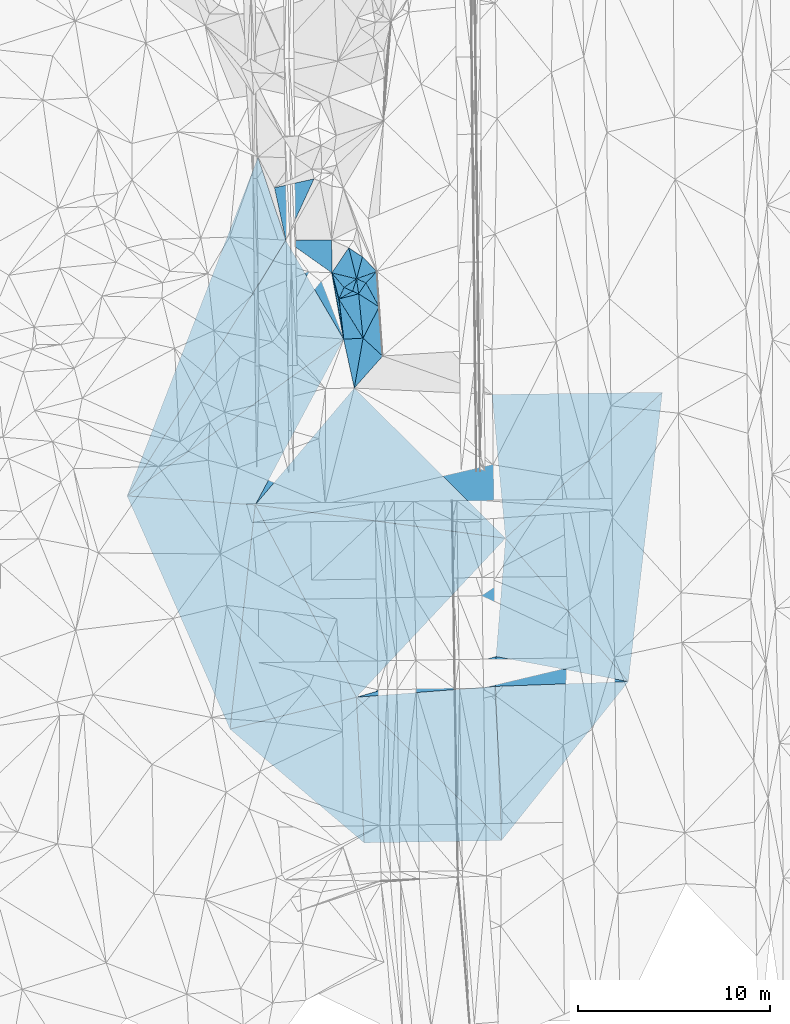
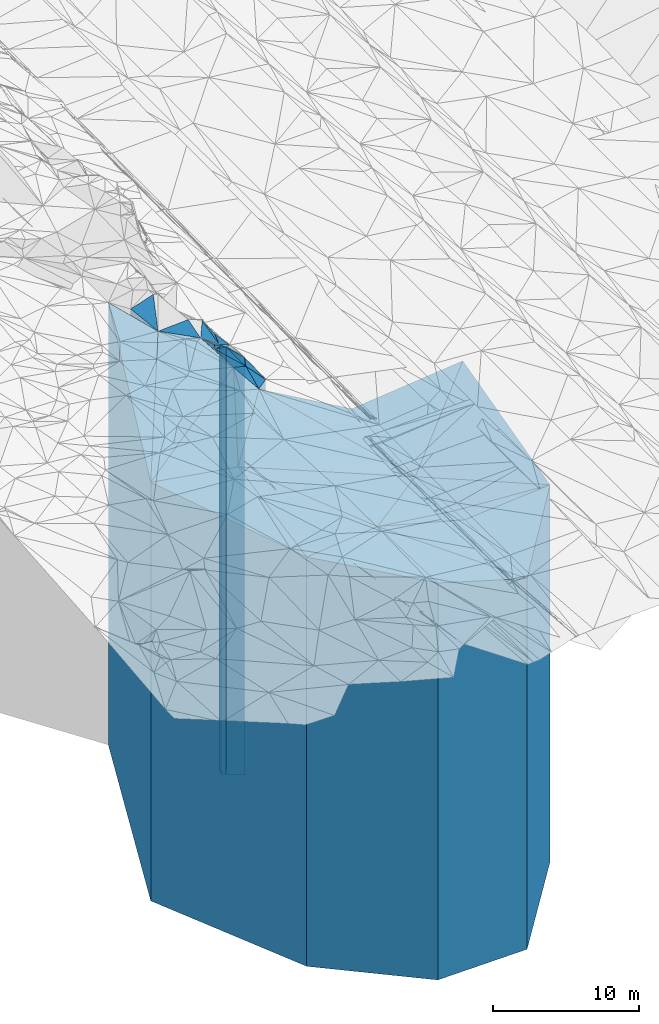
# One storey, part 196 of 275: 42 plates.
"""IFC2X3 building model written with IfcOpenShell, lengths in millimetres."""

from ifc_helpers import new_model, si_unit, frame, origin_with_axes, place, context, subcontext, project, spatial, faceted_brep, material, type_object, element, save


model = new_model("IFC2X3")

# Units and contexts
model_context = context("Model", 3, precision=1e-05, world=origin_with_axes())
body_context = subcontext(model_context, "Body", "Model", "MODEL_VIEW")
ifc_project = project(units=[si_unit("LENGTHUNIT", "METRE", prefix="MILLI"), si_unit("AREAUNIT", "SQUARE_METRE"), si_unit("VOLUMEUNIT", "CUBIC_METRE"), si_unit("MASSUNIT", "GRAM", prefix="KILO"), si_unit("TIMEUNIT", "SECOND"), si_unit("PLANEANGLEUNIT", "RADIAN"), si_unit("SOLIDANGLEUNIT", "STERADIAN"), si_unit("THERMODYNAMICTEMPERATUREUNIT", "DEGREE_CELSIUS"), si_unit("LUMINOUSINTENSITYUNIT", "LUMEN")], contexts=[model_context])

# Site, building, storey
site_placement = place(None, origin_with_axes())
site = spatial("IfcSite", under=ifc_project, at=site_placement, CompositionType="ELEMENT")
building_placement = place(site_placement, origin_with_axes())
building = spatial("IfcBuilding", under=site, at=building_placement, Name="Undefined", CompositionType="ELEMENT")
storey_placement = place(building_placement, origin_with_axes())
storey = spatial("IfcBuildingStorey", under=building, at=storey_placement, Name="Undefined", CompositionType="ELEMENT", Elevation=0.0)

# Plates
ifc_material = material()
plate_type_1 = type_object("IfcPlateType", PredefinedType="NOTDEFINED")
plate_1_placement = place(storey_placement, frame((-105305.526573937, -440.815138001315, 24982.5), z_axis=(-0.0700177739983117, -0.997545743975845, 0.0), x_axis=(-0.997545743975845, 0.0700177739983046, 0.0)))
element("IfcPlate", 1, at=plate_1_placement, inside=storey, type_object=plate_type_1, material=ifc_material, Name="00", context=body_context, shape_type="Brep", body=[
    faceted_brep([(1.45519152283669e-11, -17177.9519996643, 0.0), (491.817077636646, -17154.5, 11731.232421875), (491.817077636646, 17154.5, 11731.232421875), (1.45519152283669e-11, 17154.5, 0.0), (6685.89746093751, -17935.7919921875, 2.03817762667313e-08), (6685.89746093751, 17154.5, 2.03817762667313e-08)], [[[0, 1, 2, 3]], [[1, 4, 5, 2]], [[4, 0, 3, 5]], [[5, 3, 2]], [[4, 1, 0]]]),
])
plate_type_2 = type_object("IfcPlateType", PredefinedType="NOTDEFINED")
plate_2_placement = place(storey_placement, frame((-99640.6124086011, -18023.9448640923, 23363.5), z_axis=(-0.0167956189939975, 0.999858943642856, 0.0), x_axis=(0.999858943642856, 0.0167956189940008, 0.0)))
element("IfcPlate", 2, at=plate_2_placement, inside=storey, type_object=plate_type_2, material=ifc_material, Name="00", context=body_context, shape_type="Brep", body=[
    faceted_brep([(0.0, -17744.5048828125, -3.63797880709171e-12), (-275.485351562515, -18023.1530761719, 7580.67138671875), (-275.485351562515, 15535.5, 7580.67138671875), (0.0, 15535.5, -3.63797880709171e-12), (7152.96582031251, -15535.5, -7.49605533201247e-09), (7152.96582031251, 15535.5, -7.49605533201247e-09)], [[[0, 1, 2, 3]], [[1, 4, 5, 2]], [[4, 0, 3, 5]], [[5, 3, 2]], [[4, 1, 0]]]),
])
plate_type_3 = type_object("IfcPlateType", PredefinedType="NOTDEFINED")
plate_3_placement = place(storey_placement, frame((-92802.1248192446, -9884.44215009389, 23343.5), z_axis=(-0.0364740679928173, 0.999334599803317, 0.0), x_axis=(0.999334599803317, 0.0364740679928213, 0.0)))
element("IfcPlate", 3, at=plate_3_placement, inside=storey, type_object=plate_type_3, material=ifc_material, Name="00", context=body_context, shape_type="Brep", body=[
    faceted_brep([(-1.45519152283669e-11, -15739.6970062256, -2.72848410531878e-12), (79.7649078368995, -15515.5, 1552.5810546875), (79.7649078368995, 15515.5, 1552.5810546875), (-1.45519152283669e-11, 15515.5, -2.72848410531878e-12), (6914.56884765624, -16092.4429931641, -2.303841029061e-08), (6914.56884765624, 15515.5, -2.303841029061e-08)], [[[0, 1, 2, 3]], [[1, 4, 5, 2]], [[4, 0, 3, 5]], [[5, 3, 2]], [[4, 1, 0]]]),
])
plate_type_4 = type_object("IfcPlateType", PredefinedType="NOTDEFINED")
plate_4_placement = place(storey_placement, frame((-92802.1248192446, -9884.44215009389, 23343.5), z_axis=(-0.999889764673586, 0.0148478449951532, 0.0), x_axis=(0.0148478449951493, 0.999889764673586, 0.0)))
element("IfcPlate", 4, at=plate_4_placement, inside=storey, type_object=plate_type_4, material=ifc_material, Name="00", context=body_context, shape_type="Brep", body=[
    faceted_brep([(-1.45519152283669e-11, -15739.6970062256, -2.72848410531878e-12), (-671.982604980498, -18043.2661132813, 7232.07568359378), (-671.982604980498, 15515.5, 7232.07568359378), (-1.45519152283669e-11, 15515.5, -2.72848410531878e-12), (1554.62878417969, -15515.5, 1.44063960760832e-09), (1554.62878417969, 15515.5, 1.44063960760832e-09)], [[[0, 1, 2, 3]], [[1, 4, 5, 2]], [[4, 0, 3, 5]], [[5, 3, 2]], [[4, 1, 0]]]),
])
plate_type_5 = type_object("IfcPlateType", PredefinedType="NOTDEFINED")
plate_5_placement = place(storey_placement, frame((-92779.0419328153, -8329.98478390302, 22828.0), z_axis=(-0.996761812388552, 0.0804107540313459, 0.0), x_axis=(0.0804107540313444, 0.996761812388552, 0.0)))
element("IfcPlate", 5, at=plate_5_placement, inside=storey, type_object=plate_type_5, material=ifc_material, Name="00", context=body_context, shape_type="Brep", body=[
    faceted_brep([(-1.81898940354586e-12, -16031.3800048828, 0.0), (-2696.25439453126, -18559.1459960937, 7070.42675781251), (-2696.25439453126, 15000.0, 7070.42675781251), (-1.81898940354586e-12, 15000.0, 0.0), (6172.1572265625, -15000.0, 2.459273673594e-09), (6172.1572265625, 15000.0, 2.459273673594e-09)], [[[0, 1, 2, 3]], [[1, 4, 5, 2]], [[4, 0, 3, 5]], [[5, 3, 2]], [[4, 1, 0]]]),
])
plate_type_6 = type_object("IfcPlateType", PredefinedType="NOTDEFINED")
plate_6_placement = place(storey_placement, frame((-92488.6554805373, -17903.806377585, 23363.5), z_axis=(-0.781824832092926, 0.623498141074109, 0.0), x_axis=(0.623498141074108, 0.781824832092926, 0.0)))
element("IfcPlate", 6, at=plate_6_placement, inside=storey, type_object=plate_type_6, material=ifc_material, Name="00", context=body_context, shape_type="Brep", body=[
    faceted_brep([(0.0, -15535.5, -7.27595761418343e-12), (6074.29052734374, -15719.5839996338, 5245.13671874999), (6074.29052734374, 15535.5, 5245.13671874999), (0.0, 15535.5, -3.63797880709171e-12), (10579.8212890625, -16072.3300170898, 9.45874489843845e-09), (10579.8212890625, 15535.5, 9.45874489843845e-09)], [[[0, 1, 2, 3]], [[1, 4, 5, 2]], [[4, 0, 3, 5]], [[5, 3, 2]], [[4, 1, 0]]]),
])
plate_type_7 = type_object("IfcPlateType", PredefinedType="NOTDEFINED")
plate_7_placement = place(storey_placement, frame((-92282.7341140035, -2177.81414361556, 22828.0), z_axis=(-0.132210585969485, -0.991221650771211, 0.0), x_axis=(-0.991221650771212, 0.132210585969484, 0.0)))
element("IfcPlate", 7, at=plate_7_placement, inside=storey, type_object=plate_type_7, material=ifc_material, Name="00", context=body_context, shape_type="Brep", body=[
    faceted_brep([(-1.45519152283669e-11, -15000.0, 0.0), (6598.98681640624, -18559.1459960937, 9224.587890625), (6598.98681640624, 15000.0, 9224.587890625), (-1.81898940354586e-12, 15000.0, 0.0), (13138.123046875, -19332.0, 3.06281435769051e-08), (13138.123046875, 15000.0, 3.06281435769051e-08)], [[[0, 1, 2, 3]], [[1, 4, 5, 2]], [[4, 0, 3, 5]], [[5, 3, 2]], [[4, 1, 0]]]),
])
plate_type_8 = type_object("IfcPlateType", PredefinedType="NOTDEFINED")
plate_8_placement = place(storey_placement, frame((-100153.131483176, 5639.11864689306, 22828.0), z_axis=(0.704692771056424, 0.709512578056808, 0.0), x_axis=(0.709512578056809, -0.704692771056423, 0.0)))
element("IfcPlate", 8, at=plate_8_placement, inside=storey, type_object=plate_type_8, material=ifc_material, Name="00", context=body_context, shape_type="Brep", body=[
    faceted_brep([(0.0, -20365.0, 0.0), (5318.11376953125, -16413.5389404297, 4809.568359375), (5318.11376953125, 15000.0, 4809.568359375), (-1.81898940354586e-12, 15000.0, 0.0), (11092.681640625, -15000.0, 3.94938979297876e-08), (11092.681640625, 15000.0, 3.94938979297876e-08)], [[[0, 1, 2, 3]], [[1, 4, 5, 2]], [[4, 0, 3, 5]], [[5, 3, 2]], [[4, 1, 0]]]),
])
plate_type_9 = type_object("IfcPlateType", PredefinedType="NOTDEFINED")
plate_9_placement = place(storey_placement, frame((-92990.5948340277, 5303.93136843647, 22828.0), z_axis=(0.99555413766383, 0.0941910769681941, 0.0), x_axis=(0.0941910769681941, -0.99555413766383, 0.0)))
element("IfcPlate", 9, at=plate_9_placement, inside=storey, type_object=plate_type_9, material=ifc_material, Name="00", context=body_context, shape_type="Brep", body=[
    faceted_brep([(0.0, -16413.5389404297, 0.0), (721.031250000002, -17260.0810546875, 8839.1796875), (721.031250000002, 15000.0, 8839.1796875), (-1.81898940354586e-12, 15000.0, 0.0), (7515.15673828125, -15000.0, -5.60248736292124e-09), (7515.15673828125, 15000.0, -5.60248736292124e-09)], [[[0, 1, 2, 3]], [[1, 4, 5, 2]], [[4, 0, 3, 5]], [[5, 3, 2]], [[4, 1, 0]]]),
])
plate_type_10 = type_object("IfcPlateType", PredefinedType="NOTDEFINED")
plate_10_placement = place(storey_placement, frame((-92488.6554805373, -17903.806377585, 23363.5), z_axis=(-0.999236897424959, -0.0390592220166113, 0.0), x_axis=(-0.0390592220166118, 0.999236897424959, 0.0)))
element("IfcPlate", 10, at=plate_10_placement, inside=storey, type_object=plate_type_10, material=ifc_material, Name="00", context=body_context, shape_type="Brep", body=[
    faceted_brep([(0.0, -15535.5, -7.27595761418343e-12), (7744.22949218749, -18023.1530761719, 7257.78027343753), (7744.22949218749, 15535.5, 7257.78027343753), (0.0, 15535.5, -3.63797880709171e-12), (8025.48828125, -15719.5839996338, 1.37515598908067e-08), (8025.48828125, 15535.5, 1.37515598908067e-08)], [[[0, 1, 2, 3]], [[1, 4, 5, 2]], [[4, 0, 3, 5]], [[5, 3, 2]], [[4, 1, 0]]]),
])
plate_type_11 = type_object("IfcPlateType", PredefinedType="NOTDEFINED")
plate_11_placement = place(storey_placement, frame((-84122.7978747198, 5418.67758166406, 22828.0), z_axis=(0.681385360251635, -0.7319248532703, 0.0), x_axis=(-0.731924853270299, -0.681385360251636, 0.0)))
element("IfcPlate", 11, at=plate_11_placement, inside=storey, type_object=plate_type_11, material=ifc_material, Name="00", context=body_context, shape_type="Brep", body=[
    faceted_brep([(0.0, -17260.0810546875, -7.27595761418343e-12), (11550.5126953125, -16608.3229980469, 9810.52539062499), (11550.5126953125, 15000.0, 9810.52539062499), (-1.81898940354586e-12, 15000.0, 0.0), (11148.5986328125, -15000.0, 1.64072844199836e-08), (11148.5986328125, 15000.0, 1.64072844199836e-08)], [[[0, 1, 2, 3]], [[1, 4, 5, 2]], [[4, 0, 3, 5]], [[5, 3, 2]], [[4, 1, 0]]]),
])
plate_type_12 = type_object("IfcPlateType", PredefinedType="NOTDEFINED")
plate_12_placement = place(storey_placement, frame((-92282.7341140035, -2177.81414361556, 22828.0), z_axis=(-0.704692771056424, -0.709512578056808, 0.0), x_axis=(-0.709512578056809, 0.704692771056423, 0.0)))
element("IfcPlate", 12, at=plate_12_placement, inside=storey, type_object=plate_type_12, material=ifc_material, Name="00", context=body_context, shape_type="Brep", body=[
    faceted_brep([(-1.45519152283669e-11, -15000.0, 0.0), (10463.8857421875, -19332.0, 7944.64501953125), (10463.8857421875, 15000.0, 7944.64501953125), (-1.81898940354586e-12, 15000.0, 0.0), (11092.681640625, -20365.0, 3.94938979297876e-08), (11092.681640625, 15000.0, 3.94938979297876e-08)], [[[0, 1, 2, 3]], [[1, 4, 5, 2]], [[4, 0, 3, 5]], [[5, 3, 2]], [[4, 1, 0]]]),
])
plate_type_13 = type_object("IfcPlateType", PredefinedType="NOTDEFINED")
plate_13_placement = place(storey_placement, frame((-106617.531358908, -12108.8197869756, 24607.5), z_axis=(-0.244799226099947, 0.969573792395848, 0.0), x_axis=(0.969573792395849, 0.244799226099944, 0.0)))
element("IfcPlate", 13, at=plate_13_placement, inside=storey, type_object=plate_type_13, material=ifc_material, Name="00", context=body_context, shape_type="Brep", body=[
    faceted_brep([(0.0, -17528.9019775391, -1.81898940354586e-12), (4128.40380859379, -17552.3540039063, 10991.8134765625), (4128.40380859379, 16779.5, 10991.8134765625), (0.0, 16779.5, -1.81898940354586e-12), (6780.45410156251, -16779.5, -4.3177351471968e-08), (6780.45410156251, 16779.5, -4.3177351471968e-08)], [[[0, 1, 2, 3]], [[1, 4, 5, 2]], [[4, 0, 3, 5]], [[5, 3, 2]], [[4, 1, 0]]]),
])
plate_type_14 = type_object("IfcPlateType", PredefinedType="NOTDEFINED")
plate_14_placement = place(storey_placement, frame((-100033.858724172, 11323.9263840958, 25644.0), z_axis=(-0.966114912425455, 0.258112332113666, 0.0), x_axis=(0.258112332113666, 0.966114912425455, 0.0)))
element("IfcPlate", 14, at=plate_14_placement, inside=storey, type_object=plate_type_14, material=ifc_material, Name="00", context=body_context, shape_type="Brep", body=[
    faceted_brep([(-5.45696821063757e-12, -17816.0, 0.0), (1453.40246582031, -18966.0, 809.704406738296), (1453.40246582031, 17816.0, 809.704406738296), (-5.45696821063757e-12, 17816.0, 0.0), (1180.677734375, -17886.0, 5.0931703299284e-10), (1180.677734375, 17816.0, 5.0931703299284e-10)], [[[0, 1, 2, 3]], [[1, 4, 5, 2]], [[4, 0, 3, 5]], [[5, 3, 2]], [[4, 1, 0]]]),
])
plate_type_15 = type_object("IfcPlateType", PredefinedType="NOTDEFINED")
plate_15_placement = place(storey_placement, frame((-100033.858724172, 11323.9263840958, 25307.5), z_axis=(-0.33904307397989, 0.940770850944196, 0.0), x_axis=(0.940770850944197, 0.339043073979887, 0.0)))
element("IfcPlate", 15, at=plate_15_placement, inside=storey, type_object=plate_type_15, material=ifc_material, Name="00", context=body_context, shape_type="Brep", body=[
    faceted_brep([(0.0, -18152.5, 0.0), (673.433959960938, -18222.5, 969.786926269524), (673.433959960938, 17479.5, 969.786926269524), (0.0, 17479.5, -7.27595761418343e-12), (1122.78271484375, -17479.5, -1.07684172689915e-09), (1122.78271484375, 17479.5, -1.07684172689915e-09)], [[[0, 1, 2, 3]], [[1, 4, 5, 2]], [[4, 0, 3, 5]], [[5, 3, 2]], [[4, 1, 0]]]),
])
plate_type_16 = type_object("IfcPlateType", PredefinedType="NOTDEFINED")
plate_16_placement = place(storey_placement, frame((-99927.7260084585, 10539.8754631376, 25499.0), z_axis=(-0.832808867780761, 0.553560646854279, 0.0), x_axis=(0.553560646854269, 0.832808867780767, 0.0)))
element("IfcPlate", 16, at=plate_16_placement, inside=storey, type_object=plate_type_16, material=ifc_material, Name="00", context=body_context, shape_type="Brep", body=[
    faceted_brep([(2.18278728425503e-11, -18161.0, 0.0), (594.213684082039, -17961.0, 522.408020019531), (594.213684082039, 17671.0, 522.408020019531), (2.18278728425503e-11, 17671.0, 0.0), (687.968017578132, -17671.0, -1.92085281014442e-09), (687.968017578132, 17671.0, -1.92085281014442e-09)], [[[0, 1, 2, 3]], [[1, 4, 5, 2]], [[4, 0, 3, 5]], [[5, 3, 2]], [[4, 1, 0]]]),
])
plate_type_17 = type_object("IfcPlateType", PredefinedType="NOTDEFINED")
plate_17_placement = place(storey_placement, frame((-100033.858724172, 11323.9263840958, 25307.5), z_axis=(0.397745432997045, 0.917495814993176, 0.0), x_axis=(0.917495814993178, -0.397745432997043, 0.0)))
element("IfcPlate", 17, at=plate_17_placement, inside=storey, type_object=plate_type_17, material=ifc_material, Name="00", context=body_context, shape_type="Brep", body=[
    faceted_brep([(0.0, -18152.5, 0.0), (817.723205566392, -17479.5, 769.395751953132), (817.723205566392, 17479.5, 769.395751953132), (0.0, 17479.5, -7.27595761418343e-12), (530.75415039064, -17862.5, -7.27595761418343e-11), (530.75415039064, 17479.5, -7.27595761418343e-11)], [[[0, 1, 2, 3]], [[1, 4, 5, 2]], [[4, 0, 3, 5]], [[5, 3, 2]], [[4, 1, 0]]]),
])
plate_type_18 = type_object("IfcPlateType", PredefinedType="NOTDEFINED")
plate_18_placement = place(storey_placement, frame((-100033.858724172, 11323.9263840958, 25644.0), z_axis=(0.56983652708901, -0.821758074128351, 0.0), x_axis=(-0.821758074128351, -0.56983652708901, 0.0)))
element("IfcPlate", 18, at=plate_18_placement, inside=storey, type_object=plate_type_18, material=ifc_material, Name="00", context=body_context, shape_type="Brep", body=[
    faceted_brep([(-5.45696821063757e-12, -17816.0, 0.0), (538.21508789064, -18136.0, 415.841949462876), (538.21508789064, 17816.0, 415.841949462876), (-5.45696821063757e-12, 17816.0, 0.0), (794.292114257813, -18296.0, 2.47382558882236e-10), (794.292114257813, 17816.0, 2.47382558882236e-10)], [[[0, 1, 2, 3]], [[1, 4, 5, 2]], [[4, 0, 3, 5]], [[5, 3, 2]], [[4, 1, 0]]]),
])
plate_type_19 = type_object("IfcPlateType", PredefinedType="NOTDEFINED")
plate_19_placement = place(storey_placement, frame((-100033.858724172, 11323.9263840958, 25644.0), z_axis=(0.953346931099853, -0.301876844031621, 0.0), x_axis=(-0.301876844031619, -0.953346931099854, 0.0)))
element("IfcPlate", 19, at=plate_19_placement, inside=storey, type_object=plate_type_19, material=ifc_material, Name="00", context=body_context, shape_type="Brep", body=[
    faceted_brep([(-5.45696821063757e-12, -17816.0, 0.0), (715.433532714836, -18016.0, 337.868103027358), (715.433532714836, 17816.0, 337.868103027358), (-5.45696821063757e-12, 17816.0, 0.0), (680.147033691395, -18136.0, 1.20780896395445e-09), (680.147033691395, 17816.0, 1.20780896395445e-09)], [[[0, 1, 2, 3]], [[1, 4, 5, 2]], [[4, 0, 3, 5]], [[5, 3, 2]], [[4, 1, 0]]]),
])
plate_type_20 = type_object("IfcPlateType", PredefinedType="NOTDEFINED")
plate_20_placement = place(storey_placement, frame((-100686.574701719, 10871.3097111213, 25804.0), z_axis=(0.911947215225025, -0.410307539101247, 0.0), x_axis=(-0.410307539101247, -0.911947215225025, 0.0)))
element("IfcPlate", 20, at=plate_20_placement, inside=storey, type_object=plate_type_20, material=ifc_material, Name="00", context=body_context, shape_type="Brep", body=[
    faceted_brep([(0.0, -18136.0, 0.0), (-5.01094007492065, -17976.0, 488.338897705078), (-5.01094007492065, 17976.0, 488.338897705078), (0.0, 17976.0, 0.0), (658.559020996086, -18206.0, 4.07453626394272e-10), (658.559020996086, 17976.0, 4.07453626394272e-10)], [[[0, 1, 2, 3]], [[1, 4, 5, 2]], [[4, 0, 3, 5]], [[5, 3, 2]], [[4, 1, 0]]]),
])
plate_type_21 = type_object("IfcPlateType", PredefinedType="NOTDEFINED")
plate_21_placement = place(storey_placement, frame((-100440.985127455, 12937.0748867917, 25644.0), z_axis=(0.82863673809214, -0.559786706062245, 0.0), x_axis=(-0.559786706062248, -0.828636738092138, 0.0)))
element("IfcPlate", 21, at=plate_21_placement, inside=storey, type_object=plate_type_21, material=ifc_material, Name="00", context=body_context, shape_type="Brep", body=[
    faceted_brep([(1.45519152283669e-11, -18966.0, -1.45519152283669e-11), (1108.81018066408, -17816.0, 1240.37902832028), (1108.81018066408, 17816.0, 1240.37902832028), (-5.45696821063757e-12, 17816.0, 0.0), (1574.84130859375, -18609.0, 8.14907252788544e-10), (1574.84130859375, 17816.0, 8.14907252788544e-10)], [[[0, 1, 2, 3]], [[1, 4, 5, 2]], [[4, 0, 3, 5]], [[5, 3, 2]], [[4, 1, 0]]]),
])
plate_type_22 = type_object("IfcPlateType", PredefinedType="NOTDEFINED")
plate_22_placement = place(storey_placement, frame((-100033.858724172, 11323.9263840958, 25644.0), z_axis=(-0.232579923972546, -0.972577286885173, 0.0), x_axis=(-0.972577286885175, 0.232579923972541, 0.0)))
element("IfcPlate", 22, at=plate_22_placement, inside=storey, type_object=plate_type_22, material=ifc_material, Name="00", context=body_context, shape_type="Brep", body=[
    faceted_brep([(-5.45696821063757e-12, -17816.0, 0.0), (529.547180175796, -18296.0, 592.013305664063), (529.547180175796, 17816.0, 592.013305664063), (-5.45696821063757e-12, 17816.0, 0.0), (1325.03771972656, -18609.0, -2.74849298875779e-09), (1325.03771972656, 17816.0, -2.74849298875779e-09)], [[[0, 1, 2, 3]], [[1, 4, 5, 2]], [[4, 0, 3, 5]], [[5, 3, 2]], [[4, 1, 0]]]),
])
plate_type_23 = type_object("IfcPlateType", PredefinedType="NOTDEFINED")
plate_23_placement = place(storey_placement, frame((-100686.574701719, 10871.3097111213, 25884.0), z_axis=(-0.767233020198739, -0.641368453166135, 0.0), x_axis=(-0.641368453166134, 0.767233020198741, 0.0)))
element("IfcPlate", 23, at=plate_23_placement, inside=storey, type_object=plate_type_23, material=ifc_material, Name="00", context=body_context, shape_type="Brep", body=[
    faceted_brep([(0.0, -18056.0, 0.0), (-287.472686767578, -18126.0, 592.50268554686), (-287.472686767578, 18056.0, 592.50268554686), (0.0, 18056.0, 0.0), (991.607299804688, -18369.0, 2.91038304567337e-10), (991.607299804688, 18056.0, 2.91038304567337e-10)], [[[0, 1, 2, 3]], [[1, 4, 5, 2]], [[4, 0, 3, 5]], [[5, 3, 2]], [[4, 1, 0]]]),
])
plate_type_24 = type_object("IfcPlateType", PredefinedType="NOTDEFINED")
plate_24_placement = place(storey_placement, frame((-99696.5545952999, 8236.62563349729, 25324.0), z_axis=(-0.889861908034198, 0.45622996901753, 0.0), x_axis=(0.456229969017534, 0.889861908034196, 0.0)))
element("IfcPlate", 24, at=plate_24_placement, inside=storey, type_object=plate_type_24, material=ifc_material, Name="00", context=body_context, shape_type="Brep", body=[
    faceted_brep([(0.0, -18046.0, 0.0), (1944.10693359376, -18336.0, 1256.52221679689), (1944.10693359376, 17496.0, 1256.52221679689), (0.0, 17496.0, 0.0), (1827.26574707031, -17496.0, 2.88127921521664e-09), (1827.26574707031, 17496.0, 2.88127921521664e-09)], [[[0, 1, 2, 3]], [[1, 4, 5, 2]], [[4, 0, 3, 5]], [[5, 3, 2]], [[4, 1, 0]]]),
])
plate_type_25 = type_object("IfcPlateType", PredefinedType="NOTDEFINED")
plate_25_placement = place(storey_placement, frame((-99546.8939848024, 11112.82133297, 25324.0), z_axis=(0.832808867780761, -0.553560646854279, 0.0), x_axis=(-0.55356064685428, -0.83280886778076, 0.0)))
element("IfcPlate", 25, at=plate_25_placement, inside=storey, type_object=plate_type_25, material=ifc_material, Name="00", context=body_context, shape_type="Brep", body=[
    faceted_brep([(0.0, -17846.0, -1.45519152283669e-11), (662.530822753906, -17496.0, 1261.68652343749), (662.530822753906, 17496.0, 1261.68652343749), (0.0, 17496.0, 0.0), (687.968017578132, -18336.0, -1.94995664060116e-09), (687.968017578132, 17496.0, -1.94995664060116e-09)], [[[0, 1, 2, 3]], [[1, 4, 5, 2]], [[4, 0, 3, 5]], [[5, 3, 2]], [[4, 1, 0]]]),
])
plate_type_26 = type_object("IfcPlateType", PredefinedType="NOTDEFINED")
plate_26_placement = place(storey_placement, frame((-99927.7260084585, 10539.8754631376, 25599.0), z_axis=(0.253025938029555, -0.967459495112981, 0.0), x_axis=(-0.967459495112982, -0.253025938029551, 0.0)))
element("IfcPlate", 26, at=plate_26_placement, inside=storey, type_object=plate_type_26, material=ifc_material, Name="00", context=body_context, shape_type="Brep", body=[
    faceted_brep([(0.0, -18061.0, -7.27595761418343e-12), (359.132965087905, -17771.0, 2286.79321289063), (359.132965087905, 17771.0, 2286.79321289063), (0.0, 17771.0, -7.27595761418343e-12), (1063.67285156251, -18411.0, 4.66388883069158e-09), (1063.67285156251, 17771.0, 4.66388883069158e-09)], [[[0, 1, 2, 3]], [[1, 4, 5, 2]], [[4, 0, 3, 5]], [[5, 3, 2]], [[4, 1, 0]]]),
])
plate_type_27 = type_object("IfcPlateType", PredefinedType="NOTDEFINED")
plate_27_placement = place(storey_placement, frame((-98862.9012135535, 9862.63979060135, 25152.0), z_axis=(0.889861908034198, -0.45622996901753, 0.0), x_axis=(-0.456229969017534, -0.889861908034196, 0.0)))
element("IfcPlate", 27, at=plate_27_placement, inside=storey, type_object=plate_type_27, material=ifc_material, Name="00", context=body_context, shape_type="Brep", body=[
    faceted_brep([(1.45519152283669e-11, -17668.0, -1.45519152283669e-11), (2191.65722656251, -17324.0, 1336.56530761716), (2191.65722656251, 17324.0, 1336.56530761716), (1.45519152283669e-11, 17324.0, -1.45519152283669e-11), (1827.26574707032, -18218.0, 2.8521753847599e-09), (1827.26574707032, 17324.0, 2.8521753847599e-09)], [[[0, 1, 2, 3]], [[1, 4, 5, 2]], [[4, 0, 3, 5]], [[5, 3, 2]], [[4, 1, 0]]]),
])
plate_type_28 = type_object("IfcPlateType", PredefinedType="NOTDEFINED")
plate_28_placement = place(storey_placement, frame((-98862.9012135535, 9862.63979060135, 25307.5), z_axis=(-0.998067598895228, -0.0621374929934772, 0.0), x_axis=(-0.0621374929934777, 0.998067598895228, 0.0)))
element("IfcPlate", 28, at=plate_28_placement, inside=storey, type_object=plate_type_28, material=ifc_material, Name="00", context=body_context, shape_type="Brep", body=[
    faceted_brep([(0.0, -17512.5, 0.0), (1290.26733398438, -17862.5, 604.987854003921), (1290.26733398438, 17479.5, 604.987854003921), (0.0, 17479.5, -7.27595761418343e-12), (1845.52453613281, -17479.5, -1.28056854009628e-09), (1845.52453613281, 17479.5, -1.28056854009628e-09)], [[[0, 1, 2, 3]], [[1, 4, 5, 2]], [[4, 0, 3, 5]], [[5, 3, 2]], [[4, 1, 0]]]),
])
plate_type_29 = type_object("IfcPlateType", PredefinedType="NOTDEFINED")
plate_29_placement = place(storey_placement, frame((-100956.786438025, 10270.7386349259, 25748.5), z_axis=(-0.965748737555729, -0.259479047149314, 0.0), x_axis=(-0.259479047149319, 0.965748737555728, 0.0)))
element("IfcPlate", 29, at=plate_29_placement, inside=storey, type_object=plate_type_29, material=ifc_material, Name="00", context=body_context, shape_type="Brep", body=[
    faceted_brep([(0.0, -18261.5, 0.0), (-2085.06518554688, -17920.5, 303.085083007813), (-2085.06518554688, 17920.5, 303.085083007813), (0.0, 17920.5, 0.0), (1409.64709472657, -18504.5, 1.07684172689915e-09), (1409.64709472657, 17920.5, 1.07684172689915e-09)], [[[0, 1, 2, 3]], [[1, 4, 5, 2]], [[4, 0, 3, 5]], [[5, 3, 2]], [[4, 1, 0]]]),
])
plate_type_30 = type_object("IfcPlateType", PredefinedType="NOTDEFINED")
plate_30_placement = place(storey_placement, frame((-100153.131483176, 5639.11864689306, 25152.0), z_axis=(-0.747174829002553, 0.664627546002274, 0.0), x_axis=(0.664627546002273, 0.747174829002555, 0.0)))
element("IfcPlate", 30, at=plate_30_placement, inside=storey, type_object=plate_type_30, material=ifc_material, Name="00", context=body_context, shape_type="Brep", body=[
    faceted_brep([(0.0, -18041.0, 0.0), (2244.24536132813, -18218.0, 1385.23193359375), (2244.24536132813, 17324.0, 1385.23193359375), (1.45519152283669e-11, 17324.0, -1.45519152283669e-11), (2226.34350585937, -17324.0, 9.60426405072212e-09), (2226.34350585937, 17324.0, 9.60426405072212e-09)], [[[0, 1, 2, 3]], [[1, 4, 5, 2]], [[4, 0, 3, 5]], [[5, 3, 2]], [[4, 1, 0]]]),
])
plate_type_31 = type_object("IfcPlateType", PredefinedType="NOTDEFINED")
plate_31_placement = place(storey_placement, frame((-100708.459760696, 8178.44542857872, 25373.0), z_axis=(-0.863361815416693, -0.504585350243536, 0.0), x_axis=(-0.504585350243534, 0.863361815416694, 0.0)))
element("IfcPlate", 31, at=plate_31_placement, inside=storey, type_object=plate_type_31, material=ifc_material, Name="00", context=body_context, shape_type="Brep", body=[
    faceted_brep([(0.0, -18296.1599731445, 0.0), (-1352.43469238278, -17545.0, 13840.0537109375), (-1352.43469238278, 17545.0, 13840.0537109375), (0.0, 17545.0, 0.0), (5963.75537109375, -19255.1600341797, -1.5352270565927e-08), (5963.75537109375, 17545.0, -1.5352270565927e-08)], [[[0, 1, 2, 3]], [[1, 4, 5, 2]], [[4, 0, 3, 5]], [[5, 3, 2]], [[4, 1, 0]]]),
])
plate_type_32 = type_object("IfcPlateType", PredefinedType="NOTDEFINED")
plate_32_placement = place(storey_placement, frame((-103717.683263969, 13327.3239382497, 25373.0), z_axis=(-0.948571160165852, -0.316563981055346, 0.0), x_axis=(-0.31656398105535, 0.948571160165851, 0.0)))
element("IfcPlate", 32, at=plate_32_placement, inside=storey, type_object=plate_type_32, material=ifc_material, Name="00", context=body_context, shape_type="Brep", body=[
    faceted_brep([(0.0, -19255.1600341797, 0.0), (-10002.0292968751, -17545.0, 12042.9697265625), (-10002.0292968751, 17545.0, 12042.9697265625), (0.0, 17545.0, 0.0), (4560.22363281251, -19544.1600341797, -6.86850398778915e-09), (4560.22363281251, 17545.0, -6.86850398778915e-09)], [[[0, 1, 2, 3]], [[1, 4, 5, 2]], [[4, 0, 3, 5]], [[5, 3, 2]], [[4, 1, 0]]]),
])
plate_type_33 = type_object("IfcPlateType", PredefinedType="NOTDEFINED")
plate_33_placement = place(storey_placement, frame((-100708.459760696, 8178.44542857872, 25748.5), z_axis=(-0.984556764247798, -0.175065639044063, 0.0), x_axis=(-0.17506563904406, 0.984556764247798, 0.0)))
element("IfcPlate", 33, at=plate_33_placement, inside=storey, type_object=plate_type_33, material=ifc_material, Name="00", context=body_context, shape_type="Brep", body=[
    faceted_brep([(3.63797880709171e-12, -17920.5, 1.45519152283669e-11), (5596.17480468751, -18879.5, 2061.35961914063), (5596.17480468751, 17920.5, 2061.35961914063), (0.0, 17920.5, 0.0), (3507.83032226563, -18504.5, 6.69388100504875e-10), (3507.83032226563, 17920.5, 6.69388100504875e-10)], [[[0, 1, 2, 3]], [[1, 4, 5, 2]], [[4, 0, 3, 5]], [[5, 3, 2]], [[4, 1, 0]]]),
])
plate_type_34 = type_object("IfcPlateType", PredefinedType="NOTDEFINED")
plate_34_placement = place(storey_placement, frame((-102245.530953927, 16523.676950049, 26228.0), z_axis=(0.218992509967534, -0.975726539855363, 0.0), x_axis=(-0.975726539855362, -0.218992509967538, 0.0)))
element("IfcPlate", 34, at=plate_34_placement, inside=storey, type_object=plate_type_34, material=ifc_material, Name="00", context=body_context, shape_type="Brep", body=[
    faceted_brep([(0.0, -19042.0, 0.0), (2136.39550781249, -18400.0, 2796.37622070313), (2136.39550781249, 18400.0, 2796.37622070313), (0.0, 18400.0, 0.0), (2110.21337890625, -18812.0, 1.51776475831866e-08), (2110.21337890625, 18400.0, 1.51776475831866e-08)], [[[0, 1, 2, 3]], [[1, 4, 5, 2]], [[4, 0, 3, 5]], [[5, 3, 2]], [[4, 1, 0]]]),
])
plate_type_35 = type_object("IfcPlateType", PredefinedType="NOTDEFINED")
plate_35_placement = place(storey_placement, frame((-105305.526573937, -440.815138001315, 24994.0), z_axis=(-0.762901243138064, 0.646515037117001, 0.0), x_axis=(0.646515037117001, 0.762901243138064, 0.0)))
element("IfcPlate", 35, at=plate_35_placement, inside=storey, type_object=plate_type_35, material=ifc_material, Name="00", context=body_context, shape_type="Brep", body=[
    faceted_brep([(-1.45519152283669e-11, -17166.0, 1.45519152283669e-11), (9547.7177734375, -18675.0, 2065.37353515626), (9547.7177734375, 17166.0, 2065.37353515626), (-1.45519152283669e-11, 17166.0, 1.45519152283669e-11), (7969.48974609374, -18199.0, -2.04163370653987e-08), (7969.48974609374, 17166.0, -2.04163370653987e-08)], [[[0, 1, 2, 3]], [[1, 4, 5, 2]], [[4, 0, 3, 5]], [[5, 3, 2]], [[4, 1, 0]]]),
])
plate_type_36 = type_object("IfcPlateType", PredefinedType="NOTDEFINED")
plate_36_placement = place(storey_placement, frame((-101326.629958963, 13332.7176959288, 26040.5), z_axis=(0.00225580199926751, -0.999997455675433, 0.0), x_axis=(-0.999997455675433, -0.00225580199926756, 0.0)))
element("IfcPlate", 36, at=plate_36_placement, inside=storey, type_object=plate_type_36, material=ifc_material, Name="00", context=body_context, shape_type="Brep", body=[
    faceted_brep([(0.0, -18719.5, 1.81898940354586e-12), (-0.233369335532188, -18212.5, 1700.61901855469), (-0.233369335532188, 18212.5, 1700.61901855469), (-7.27595761418343e-12, 18212.5, 0.0), (2391.05932617188, -18587.5, -5.78438630327582e-10), (2391.05932617188, 18212.5, -5.78438630327582e-10)], [[[0, 1, 2, 3]], [[1, 4, 5, 2]], [[4, 0, 3, 5]], [[5, 3, 2]], [[4, 1, 0]]]),
])
plate_type_37 = type_object("IfcPlateType", PredefinedType="NOTDEFINED")
plate_37_placement = place(storey_placement, frame((-111975.015180921, 27.3165254084306, 24994.0), z_axis=(0.0700177739983117, 0.997545743975845, 0.0), x_axis=(0.997545743975845, -0.0700177739983046, 0.0)))
element("IfcPlate", 37, at=plate_37_placement, inside=storey, type_object=plate_type_37, material=ifc_material, Name="00", context=body_context, shape_type="Brep", body=[
    faceted_brep([(-2.91038304567337e-11, -17923.8400268555, -9.09494701772928e-13), (10668.1806640624, -18675.0, 8919.9833984375), (10668.1806640624, 17166.0, 8919.9833984375), (-1.45519152283669e-11, 17166.0, 1.45519152283669e-11), (6685.89746093749, -17166.0, 2.03745003091171e-08), (6685.89746093749, 17166.0, 2.03745003091171e-08)], [[[0, 1, 2, 3]], [[1, 4, 5, 2]], [[4, 0, 3, 5]], [[5, 3, 2]], [[4, 1, 0]]]),
])
plate_type_38 = type_object("IfcPlateType", PredefinedType="NOTDEFINED")
plate_38_placement = place(storey_placement, frame((-100239.179366616, 10675.510287915, 25744.0), z_axis=(0.491291412838861, -0.870995262714325, 0.0), x_axis=(-0.870995262714325, -0.491291412838861, 0.0)))
element("IfcPlate", 38, at=plate_38_placement, inside=storey, type_object=plate_type_38, material=ifc_material, Name="00", context=body_context, shape_type="Brep", body=[
    faceted_brep([(-1.45519152283669e-11, -18036.0, 1.45519152283669e-11), (-204.638168334946, -17916.0, 271.151641845696), (-204.638168334946, 17916.0, 271.151641845696), (1.45519152283669e-11, 17916.0, -7.27595761418343e-12), (823.893188476577, -18266.0, -2.01544025912881e-09), (823.893188476577, 17916.0, -2.01544025912881e-09)], [[[0, 1, 2, 3]], [[1, 4, 5, 2]], [[4, 0, 3, 5]], [[5, 3, 2]], [[4, 1, 0]]]),
])
plate_type_39 = type_object("IfcPlateType", PredefinedType="NOTDEFINED")
plate_39_placement = place(storey_placement, frame((-106617.531358908, -12108.8197869756, 24468.0), z_axis=(0.646679602167327, 0.762761753197359, 0.0), x_axis=(0.76276175319736, -0.646679602167325, 0.0)))
element("IfcPlate", 39, at=plate_39_placement, inside=storey, type_object=plate_type_39, material=ifc_material, Name="00", context=body_context, shape_type="Brep", body=[
    faceted_brep([(0.0, -17668.0500488281, 0.0), (3941.11938476561, -16918.6480102539, 5517.43896484375), (3941.11938476561, 16640.0, 5517.43896484375), (0.0, 16640.0, 0.0), (9146.91796874999, -16640.0, 3.40514816343784e-08), (9146.91796874999, 16640.0, 3.40514816343784e-08)], [[[0, 1, 2, 3]], [[1, 4, 5, 2]], [[4, 0, 3, 5]], [[5, 3, 2]], [[4, 1, 0]]]),
])
plate_type_40 = type_object("IfcPlateType", PredefinedType="NOTDEFINED")
plate_40_placement = place(storey_placement, frame((-99696.5545952999, 8236.62563349729, 25510.5), z_axis=(0.0574009110258723, -0.998351208449912, 0.0), x_axis=(-0.998351208449912, -0.0574009110258676, 0.0)))
element("IfcPlate", 40, at=plate_40_placement, inside=storey, type_object=plate_type_40, material=ifc_material, Name="00", context=body_context, shape_type="Brep", body=[
    faceted_brep([(-1.45519152283669e-11, -17859.5, 0.0), (604.923339843735, -17682.5, 2567.01635742187), (604.923339843735, 17682.5, 2567.01635742187), (-1.45519152283669e-11, 17682.5, 0.0), (1013.57635498045, -18158.5, 2.99223756883293e-09), (1013.57635498045, 17682.5, 2.99223756883293e-09)], [[[0, 1, 2, 3]], [[1, 4, 5, 2]], [[4, 0, 3, 5]], [[5, 3, 2]], [[4, 1, 0]]]),
])
plate_type_41 = type_object("IfcPlateType", PredefinedType="NOTDEFINED")
plate_41_placement = place(storey_placement, frame((-100956.786438025, 10270.7386349259, 25599.0), z_axis=(0.99303032098944, 0.117859159998747, 0.0), x_axis=(0.117859159998745, -0.99303032098944, 0.0)))
element("IfcPlate", 41, at=plate_41_placement, inside=storey, type_object=plate_type_41, material=ifc_material, Name="00", context=body_context, shape_type="Brep", body=[
    faceted_brep([(0.0, -18411.0, 0.0), (2168.4658203125, -17771.0, 1011.70959472656), (2168.4658203125, 17771.0, 1011.70959472656), (0.0, 17771.0, -7.27595761418343e-12), (2106.97827148438, -18070.0, -6.98491930961609e-10), (2106.97827148438, 17771.0, -6.98491930961609e-10)], [[[0, 1, 2, 3]], [[1, 4, 5, 2]], [[4, 0, 3, 5]], [[5, 3, 2]], [[4, 1, 0]]]),
])
plate_type_42 = type_object("IfcPlateType", PredefinedType="NOTDEFINED")
plate_42_placement = place(storey_placement, frame((-92779.0419328153, -8329.98478390302, 22828.0), z_axis=(0.185799475028473, 0.982587683150539, 0.0), x_axis=(0.98258768315054, -0.185799475028466, 0.0)))
element("IfcPlate", 42, at=plate_42_placement, inside=storey, type_object=plate_type_42, material=ifc_material, Name="00", context=body_context, shape_type="Brep", body=[
    faceted_brep([(-1.81898940354586e-12, -16031.3800048828, 0.0), (-655.404113769589, -15000.0, 6137.2607421875), (-655.404113769589, 15000.0, 6137.2607421875), (-1.81898940354586e-12, 15000.0, 0.0), (7008.92675781249, -16608.3229980469, -5.00913301948458e-08), (7008.92675781249, 15000.0, -5.00913301948458e-08)], [[[0, 1, 2, 3]], [[1, 4, 5, 2]], [[4, 0, 3, 5]], [[5, 3, 2]], [[4, 1, 0]]]),
])

save(model, "model.ifc")
